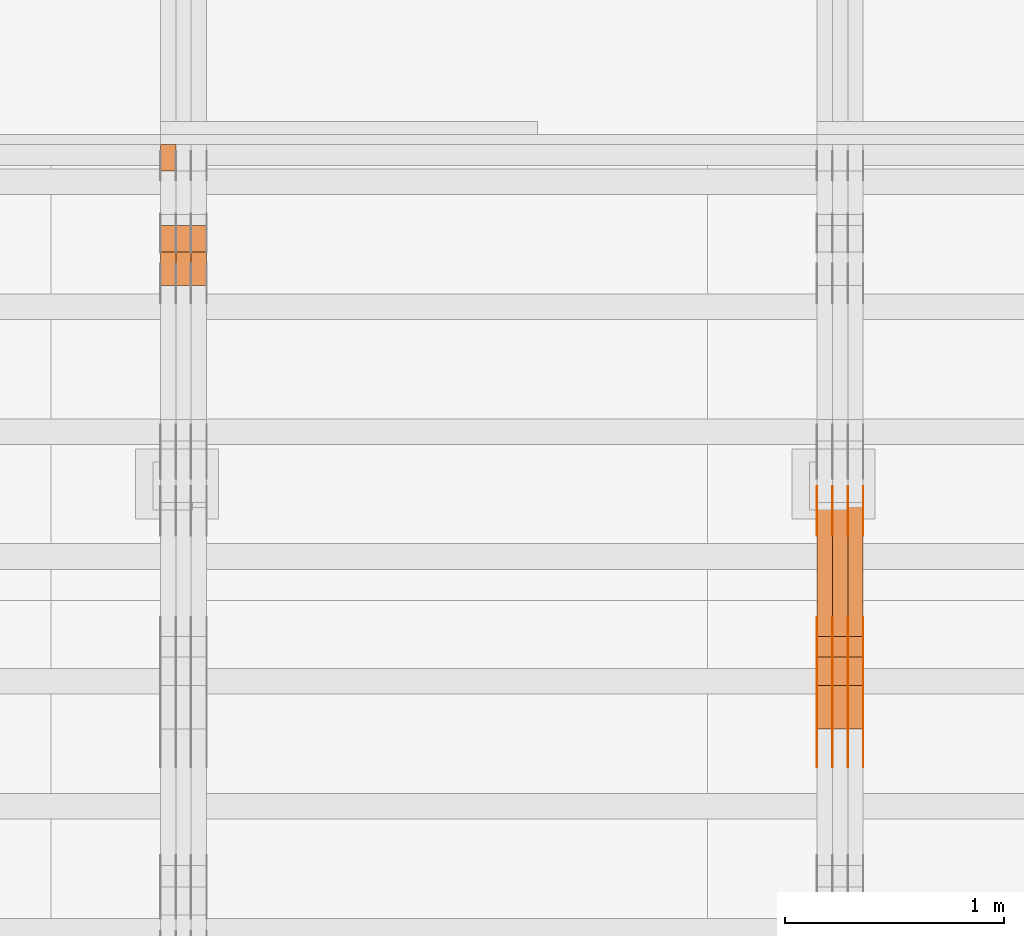
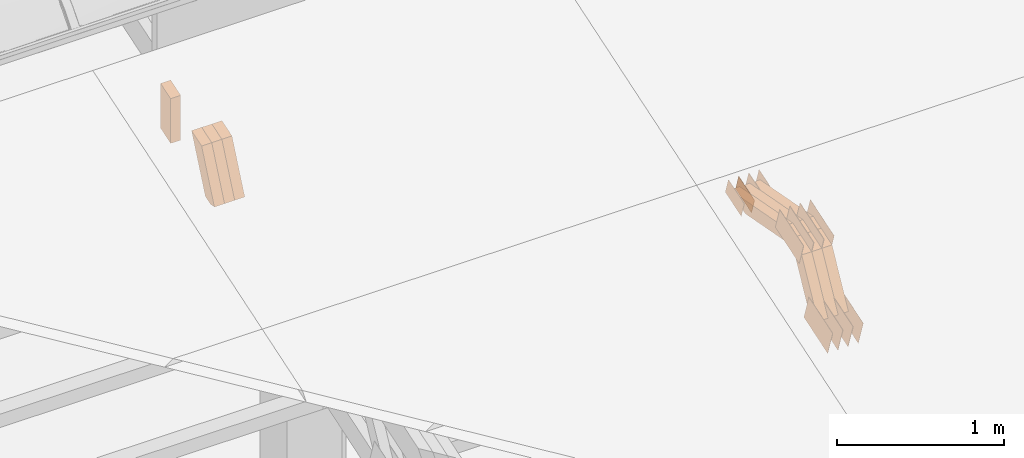
# One storey, part 158 of 385: 28 proxies.
"""IFC2X3 building model written with IfcOpenShell, lengths in millimetres."""

from ifc_helpers import new_model, entity, si_unit, converted_unit, derived_unit, direction, frame, origin, place, context, subcontext, project, spatial, polyline, outline, extrude, source, transform, mapped, material, type_object, type_shapes, element, save


model = new_model("IFC2X3")

# Units and contexts
model_context = context("Model", 3, precision=0.01, world=origin(), true_north=direction((6.12303176911189e-17, 1.0)))
body_context = subcontext(model_context, "Body", "Model", "MODEL_VIEW")
ifc_project = project(units=[si_unit("LENGTHUNIT", "METRE", prefix="MILLI"), si_unit("AREAUNIT", "SQUARE_METRE"), si_unit("VOLUMEUNIT", "CUBIC_METRE"), converted_unit("PLANEANGLEUNIT", "DEGREE", entity("IfcRatioMeasure", 0.0174532925199433), si_unit("PLANEANGLEUNIT", "RADIAN"), dimensions=[0, 0, 0, 0, 0, 0, 0]), si_unit("MASSUNIT", "GRAM", prefix="KILO"), derived_unit("MASSDENSITYUNIT", [(si_unit("MASSUNIT", "GRAM", prefix="KILO"), 1), (si_unit("LENGTHUNIT", "METRE"), -3)]), si_unit("TIMEUNIT", "SECOND"), si_unit("FREQUENCYUNIT", "HERTZ"), si_unit("THERMODYNAMICTEMPERATUREUNIT", "DEGREE_CELSIUS"), derived_unit("THERMALTRANSMITTANCEUNIT", [(si_unit("MASSUNIT", "GRAM", prefix="KILO"), 1), (si_unit("THERMODYNAMICTEMPERATUREUNIT", "KELVIN"), -1), (si_unit("TIMEUNIT", "SECOND"), -3)]), derived_unit("VOLUMETRICFLOWRATEUNIT", [(si_unit("LENGTHUNIT", "METRE"), 3), (si_unit("TIMEUNIT", "SECOND"), -1)]), si_unit("ELECTRICCURRENTUNIT", "AMPERE"), si_unit("ELECTRICVOLTAGEUNIT", "VOLT"), si_unit("POWERUNIT", "WATT"), si_unit("FORCEUNIT", "NEWTON", prefix="KILO"), si_unit("ILLUMINANCEUNIT", "LUX"), si_unit("LUMINOUSFLUXUNIT", "LUMEN"), si_unit("LUMINOUSINTENSITYUNIT", "CANDELA"), derived_unit("USERDEFINED", [(si_unit("MASSUNIT", "GRAM", prefix="KILO"), -1), (si_unit("LENGTHUNIT", "METRE"), -2), (si_unit("TIMEUNIT", "SECOND"), 3), (si_unit("LUMINOUSFLUXUNIT", "LUMEN"), 1)]), derived_unit("LINEARVELOCITYUNIT", [(si_unit("LENGTHUNIT", "METRE"), 1), (si_unit("TIMEUNIT", "SECOND"), -1)]), si_unit("PRESSUREUNIT", "PASCAL"), derived_unit("USERDEFINED", [(si_unit("LENGTHUNIT", "METRE"), -2), (si_unit("MASSUNIT", "GRAM", prefix="KILO"), 1), (si_unit("TIMEUNIT", "SECOND"), -2)])], contexts=[model_context])

# Site, building, storey
site_placement = place(None, origin())
site = spatial("IfcSite", under=ifc_project, at=site_placement, CompositionType="ELEMENT")
building_placement = place(site_placement, origin())
building = spatial("IfcBuilding", under=site, at=building_placement, CompositionType="ELEMENT")
storey_placement = place(building_placement, origin())
storey = spatial("IfcBuildingStorey", under=building, at=storey_placement, Name="Default", CompositionType="ELEMENT", Elevation=0.0)

# Proxies
ifc_material_1 = material(Name="IfcSurfaceStyle #380616")
building_element_proxy_type_1 = type_object("IfcBuildingElementProxyType", PredefinedType="NOTDEFINED", material=ifc_material_1)
shared_shape_1 = source(origin(), body_context, "Body", "SweptSolid", [
    extrude(outline(polyline([(-149.99966632326, -95.9999759039407), (149.999881095801, -95.9999759039407), (150.000557367591, 95.9999759039407), (-150.000772140132, 95.9999759039406), (-149.99966632326, -95.9999759039407)])), frame((150.000557367591, 96.0004291135906, 0.0), z_axis=(0.0, 0.0, 1.0), x_axis=(-1.0, 0.0, 0.0)), (0.0, 0.0, 1.0), 1.29999999999999),
])
type_shapes(building_element_proxy_type_1, [shared_shape_1])
proxy_1_placement = place(building_placement, frame((30386.3, 10934.7734375, 2766.8759765625), z_axis=(-1.0, 0.0, 0.0), x_axis=(0.0, 0.951056516295124, 0.309016994375039)))
element("IfcBuildingElementProxy", 1, at=proxy_1_placement, inside=storey, type_object=building_element_proxy_type_1, material=ifc_material_1, context=body_context, shape_type="MappedRepresentation", body=[
    mapped(shared_shape_1, transform((0.0, 0.0, 0.0), scale=1.0)),
])
ifc_material_2 = material(Name="IfcSurfaceStyle #380559")
building_element_proxy_type_2 = type_object("IfcBuildingElementProxyType", PredefinedType="NOTDEFINED", material=ifc_material_2)
shared_shape_2 = source(origin(), body_context, "Body", "SweptSolid", [
    extrude(outline(polyline([(-149.99966632326, -95.9999759039407), (149.999881095801, -95.9999759039407), (150.000557367591, 95.9999759039407), (-150.000772140132, 95.9999759039406), (-149.99966632326, -95.9999759039407)])), frame((150.000557367591, 96.0004291135906, 0.0), z_axis=(0.0, 0.0, 1.0), x_axis=(-1.0, 0.0, 0.0)), (0.0, 0.0, 1.0), 1.29999999999999),
])
type_shapes(building_element_proxy_type_2, [shared_shape_2])
proxy_2_placement = place(building_placement, frame((30315.0, 10934.7734375, 2766.8759765625), z_axis=(-1.0, 0.0, 0.0), x_axis=(0.0, 0.951056516295124, 0.309016994375039)))
element("IfcBuildingElementProxy", 2, at=proxy_2_placement, inside=storey, type_object=building_element_proxy_type_2, material=ifc_material_2, context=body_context, shape_type="MappedRepresentation", body=[
    mapped(shared_shape_2, transform((0.0, 0.0, 0.0), scale=1.0)),
])
ifc_material_3 = material(Name="IfcSurfaceStyle #380502")
building_element_proxy_type_3 = type_object("IfcBuildingElementProxyType", PredefinedType="NOTDEFINED", material=ifc_material_3)
shared_shape_3 = source(origin(), body_context, "Body", "SweptSolid", [
    extrude(outline(polyline([(-149.99966632326, -95.9999759039407), (149.999881095801, -95.9999759039407), (150.000557367591, 95.9999759039407), (-150.000772140132, 95.9999759039406), (-149.99966632326, -95.9999759039407)])), frame((150.000557367591, 96.0004291135906, 0.0), z_axis=(0.0, 0.0, 1.0), x_axis=(-1.0, 0.0, 0.0)), (0.0, 0.0, 1.0), 1.29999999999999),
])
type_shapes(building_element_proxy_type_3, [shared_shape_3])
proxy_3_placement = place(building_placement, frame((30316.3, 10934.7734375, 2766.8759765625), z_axis=(-1.0, 0.0, 0.0), x_axis=(0.0, 0.951056516295124, 0.309016994375039)))
element("IfcBuildingElementProxy", 3, at=proxy_3_placement, inside=storey, type_object=building_element_proxy_type_3, material=ifc_material_3, context=body_context, shape_type="MappedRepresentation", body=[
    mapped(shared_shape_3, transform((0.0, 0.0, 0.0), scale=1.0)),
])
ifc_material_4 = material(Name="IfcSurfaceStyle #380445")
building_element_proxy_type_4 = type_object("IfcBuildingElementProxyType", PredefinedType="NOTDEFINED", material=ifc_material_4)
shared_shape_4 = source(origin(), body_context, "Body", "SweptSolid", [
    extrude(outline(polyline([(-149.99966632326, -95.9999759039407), (149.999881095801, -95.9999759039407), (150.000557367591, 95.9999759039407), (-150.000772140132, 95.9999759039406), (-149.99966632326, -95.9999759039407)])), frame((150.000557367591, 96.0004291135906, 0.0), z_axis=(0.0, 0.0, 1.0), x_axis=(-1.0, 0.0, 0.0)), (0.0, 0.0, 1.0), 1.29999999999998),
])
type_shapes(building_element_proxy_type_4, [shared_shape_4])
proxy_4_placement = place(building_placement, frame((30245.0, 10934.7734375, 2766.8759765625), z_axis=(-1.0, 0.0, 0.0), x_axis=(0.0, 0.951056516295124, 0.309016994375039)))
element("IfcBuildingElementProxy", 4, at=proxy_4_placement, inside=storey, type_object=building_element_proxy_type_4, material=ifc_material_4, context=body_context, shape_type="MappedRepresentation", body=[
    mapped(shared_shape_4, transform((0.0, 0.0, 0.0), scale=1.0)),
])
ifc_material_5 = material(Name="IfcSurfaceStyle #380388")
building_element_proxy_type_5 = type_object("IfcBuildingElementProxyType", PredefinedType="NOTDEFINED", material=ifc_material_5)
shared_shape_5 = source(origin(), body_context, "Body", "SweptSolid", [
    extrude(outline(polyline([(-149.99966632326, -95.9999759039407), (149.999881095801, -95.9999759039407), (150.000557367591, 95.9999759039407), (-150.000772140132, 95.9999759039406), (-149.99966632326, -95.9999759039407)])), frame((150.000557367591, 96.0004291135906, 0.0), z_axis=(0.0, 0.0, 1.0), x_axis=(-1.0, 0.0, 0.0)), (0.0, 0.0, 1.0), 1.29999999999998),
])
type_shapes(building_element_proxy_type_5, [shared_shape_5])
proxy_5_placement = place(building_placement, frame((30246.3, 10934.7734375, 2766.8759765625), z_axis=(-1.0, 0.0, 0.0), x_axis=(0.0, 0.951056516295124, 0.309016994375039)))
element("IfcBuildingElementProxy", 5, at=proxy_5_placement, inside=storey, type_object=building_element_proxy_type_5, material=ifc_material_5, context=body_context, shape_type="MappedRepresentation", body=[
    mapped(shared_shape_5, transform((0.0, 0.0, 0.0), scale=1.0)),
])
ifc_material_6 = material(Name="IfcSurfaceStyle #380331")
building_element_proxy_type_6 = type_object("IfcBuildingElementProxyType", PredefinedType="NOTDEFINED", material=ifc_material_6)
shared_shape_6 = source(origin(), body_context, "Body", "SweptSolid", [
    extrude(outline(polyline([(-149.99966632326, -95.9999759039407), (149.999881095801, -95.9999759039407), (150.000557367591, 95.9999759039407), (-150.000772140132, 95.9999759039406), (-149.99966632326, -95.9999759039407)])), frame((150.000557367591, 96.0004291135906, 0.0), z_axis=(0.0, 0.0, 1.0), x_axis=(-1.0, 0.0, 0.0)), (0.0, 0.0, 1.0), 1.29999999999998),
])
type_shapes(building_element_proxy_type_6, [shared_shape_6])
proxy_6_placement = place(building_placement, frame((30175.0, 10934.7734375, 2766.8759765625), z_axis=(-1.0, 0.0, 0.0), x_axis=(0.0, 0.951056516295124, 0.309016994375039)))
element("IfcBuildingElementProxy", 6, at=proxy_6_placement, inside=storey, type_object=building_element_proxy_type_6, material=ifc_material_6, context=body_context, shape_type="MappedRepresentation", body=[
    mapped(shared_shape_6, transform((0.0, 0.0, 0.0), scale=1.0)),
])
ifc_material_7 = material(Name="IfcSurfaceStyle #379248")
building_element_proxy_type_7 = type_object("IfcBuildingElementProxyType", PredefinedType="NOTDEFINED", material=ifc_material_7)
shared_shape_7 = source(origin(), body_context, "Body", "SweptSolid", [
    extrude(outline(polyline([(-99.9997874178038, -60.0000528641967), (99.9998102700997, -60.0000528641967), (99.9998251396068, 60.0000528641967), (-99.9998479919027, 60.0000528641967), (-99.9997874178038, -60.0000528641967)])), frame((99.9999918898597, 60.0000528641967, 0.0), z_axis=(0.0, 0.0, 1.0), x_axis=(-1.0, 0.0, 0.0)), (0.0, 0.0, 1.0), 1.3),
])
type_shapes(building_element_proxy_type_7, [shared_shape_7])
proxy_7_placement = place(building_placement, frame((30386.3, 11991.9568177725, 3072.52282247925), z_axis=(-1.0, 0.0, 0.0), x_axis=(0.0, 0.951056516295124, 0.309016994375039)))
element("IfcBuildingElementProxy", 7, at=proxy_7_placement, inside=storey, type_object=building_element_proxy_type_7, material=ifc_material_7, context=body_context, shape_type="MappedRepresentation", body=[
    mapped(shared_shape_7, transform((0.0, 0.0, 0.0), scale=1.0)),
])
ifc_material_8 = material(Name="IfcSurfaceStyle #379191")
building_element_proxy_type_8 = type_object("IfcBuildingElementProxyType", PredefinedType="NOTDEFINED", material=ifc_material_8)
shared_shape_8 = source(origin(), body_context, "Body", "SweptSolid", [
    extrude(outline(polyline([(-99.9997874178038, -60.0000528641967), (99.9998102700997, -60.0000528641967), (99.9998251396068, 60.0000528641967), (-99.9998479919027, 60.0000528641967), (-99.9997874178038, -60.0000528641967)])), frame((99.9999918898597, 60.0000528641967, 0.0), z_axis=(0.0, 0.0, 1.0), x_axis=(-1.0, 0.0, 0.0)), (0.0, 0.0, 1.0), 1.3),
])
type_shapes(building_element_proxy_type_8, [shared_shape_8])
proxy_8_placement = place(building_placement, frame((30315.0, 11991.9568177725, 3072.52282247925), z_axis=(-1.0, 0.0, 0.0), x_axis=(0.0, 0.951056516295124, 0.309016994375039)))
element("IfcBuildingElementProxy", 8, at=proxy_8_placement, inside=storey, type_object=building_element_proxy_type_8, material=ifc_material_8, context=body_context, shape_type="MappedRepresentation", body=[
    mapped(shared_shape_8, transform((0.0, 0.0, 0.0), scale=1.0)),
])
ifc_material_9 = material(Name="IfcSurfaceStyle #379134")
building_element_proxy_type_9 = type_object("IfcBuildingElementProxyType", PredefinedType="NOTDEFINED", material=ifc_material_9)
shared_shape_9 = source(origin(), body_context, "Body", "SweptSolid", [
    extrude(outline(polyline([(-99.9997874178038, -60.0000528641967), (99.9998102700997, -60.0000528641967), (99.9998251396068, 60.0000528641967), (-99.9998479919027, 60.0000528641967), (-99.9997874178038, -60.0000528641967)])), frame((99.9999918898597, 60.0000528641967, 0.0), z_axis=(0.0, 0.0, 1.0), x_axis=(-1.0, 0.0, 0.0)), (0.0, 0.0, 1.0), 1.3),
])
type_shapes(building_element_proxy_type_9, [shared_shape_9])
proxy_9_placement = place(building_placement, frame((30316.3, 11991.9568177725, 3072.52282247925), z_axis=(-1.0, 0.0, 0.0), x_axis=(0.0, 0.951056516295124, 0.309016994375039)))
element("IfcBuildingElementProxy", 9, at=proxy_9_placement, inside=storey, type_object=building_element_proxy_type_9, material=ifc_material_9, context=body_context, shape_type="MappedRepresentation", body=[
    mapped(shared_shape_9, transform((0.0, 0.0, 0.0), scale=1.0)),
])
ifc_material_10 = material(Name="IfcSurfaceStyle #379077")
building_element_proxy_type_10 = type_object("IfcBuildingElementProxyType", PredefinedType="NOTDEFINED", material=ifc_material_10)
shared_shape_10 = source(origin(), body_context, "Body", "SweptSolid", [
    extrude(outline(polyline([(-99.9997874178038, -60.0000528641967), (99.9998102700997, -60.0000528641967), (99.9998251396068, 60.0000528641967), (-99.9998479919027, 60.0000528641967), (-99.9997874178038, -60.0000528641967)])), frame((99.9999918898597, 60.0000528641967, 0.0), z_axis=(0.0, 0.0, 1.0), x_axis=(-1.0, 0.0, 0.0)), (0.0, 0.0, 1.0), 1.29999999999998),
])
type_shapes(building_element_proxy_type_10, [shared_shape_10])
proxy_10_placement = place(building_placement, frame((30245.0, 11991.9568177725, 3072.52282247925), z_axis=(-1.0, 0.0, 0.0), x_axis=(0.0, 0.951056516295124, 0.309016994375039)))
element("IfcBuildingElementProxy", 10, at=proxy_10_placement, inside=storey, type_object=building_element_proxy_type_10, material=ifc_material_10, context=body_context, shape_type="MappedRepresentation", body=[
    mapped(shared_shape_10, transform((0.0, 0.0, 0.0), scale=1.0)),
])
ifc_material_11 = material(Name="IfcSurfaceStyle #379020")
building_element_proxy_type_11 = type_object("IfcBuildingElementProxyType", PredefinedType="NOTDEFINED", material=ifc_material_11)
shared_shape_11 = source(origin(), body_context, "Body", "SweptSolid", [
    extrude(outline(polyline([(-99.9997874178038, -60.0000528641967), (99.9998102700997, -60.0000528641967), (99.9998251396068, 60.0000528641967), (-99.9998479919027, 60.0000528641967), (-99.9997874178038, -60.0000528641967)])), frame((99.9999918898597, 60.0000528641967, 0.0), z_axis=(0.0, 0.0, 1.0), x_axis=(-1.0, 0.0, 0.0)), (0.0, 0.0, 1.0), 1.29999999999998),
])
type_shapes(building_element_proxy_type_11, [shared_shape_11])
proxy_11_placement = place(building_placement, frame((30246.3, 11991.9568177725, 3072.52282247925), z_axis=(-1.0, 0.0, 0.0), x_axis=(0.0, 0.951056516295124, 0.309016994375039)))
element("IfcBuildingElementProxy", 11, at=proxy_11_placement, inside=storey, type_object=building_element_proxy_type_11, material=ifc_material_11, context=body_context, shape_type="MappedRepresentation", body=[
    mapped(shared_shape_11, transform((0.0, 0.0, 0.0), scale=1.0)),
])
ifc_material_12 = material(Name="IfcSurfaceStyle #378963")
building_element_proxy_type_12 = type_object("IfcBuildingElementProxyType", PredefinedType="NOTDEFINED", material=ifc_material_12)
shared_shape_12 = source(origin(), body_context, "Body", "SweptSolid", [
    extrude(outline(polyline([(-99.9997874178038, -60.0000528641967), (99.9998102700997, -60.0000528641967), (99.9998251396068, 60.0000528641967), (-99.9998479919027, 60.0000528641967), (-99.9997874178038, -60.0000528641967)])), frame((99.9999918898597, 60.0000528641967, 0.0), z_axis=(0.0, 0.0, 1.0), x_axis=(-1.0, 0.0, 0.0)), (0.0, 0.0, 1.0), 1.29999999999999),
])
type_shapes(building_element_proxy_type_12, [shared_shape_12])
proxy_12_placement = place(building_placement, frame((30175.0, 11991.9568177725, 3072.52282247925), z_axis=(-1.0, 0.0, 0.0), x_axis=(0.0, 0.951056516295124, 0.309016994375039)))
element("IfcBuildingElementProxy", 12, at=proxy_12_placement, inside=storey, type_object=building_element_proxy_type_12, material=ifc_material_12, context=body_context, shape_type="MappedRepresentation", body=[
    mapped(shared_shape_12, transform((0.0, 0.0, 0.0), scale=1.0)),
])
ifc_material_13 = material(Name="IfcSurfaceStyle #371040")
building_element_proxy_type_13 = type_object("IfcBuildingElementProxyType", PredefinedType="NOTDEFINED", material=ifc_material_13)
shared_shape_13 = source(origin(), body_context, "Body", "SweptSolid", [
    extrude(outline(polyline([(-150.000273478628, -84.0002987844282), (149.999198496832, -84.0002987844282), (150.000273478627, 84.0002987844282), (-149.999198496831, 84.0002987844282), (-150.000273478628, -84.0002987844282)])), frame((150.000273478627, 84.0002987844282, 0.0), z_axis=(0.0, 0.0, 1.0), x_axis=(-1.0, 0.0, 0.0)), (0.0, 0.0, 1.0), 1.29999999999999),
])
type_shapes(building_element_proxy_type_13, [shared_shape_13])
proxy_13_placement = place(building_placement, frame((30386.3, 11283.0116722926, 3194.09682266857), z_axis=(-1.0, 0.0, 0.0), x_axis=(0.0, 0.951056516295154, 0.309016994374948)))
element("IfcBuildingElementProxy", 13, at=proxy_13_placement, inside=storey, type_object=building_element_proxy_type_13, material=ifc_material_13, context=body_context, shape_type="MappedRepresentation", body=[
    mapped(shared_shape_13, transform((0.0, 0.0, 0.0), scale=1.0)),
])
ifc_material_14 = material(Name="IfcSurfaceStyle #370983")
building_element_proxy_type_14 = type_object("IfcBuildingElementProxyType", PredefinedType="NOTDEFINED", material=ifc_material_14)
shared_shape_14 = source(origin(), body_context, "Body", "SweptSolid", [
    extrude(outline(polyline([(-150.000273478628, -84.0002987844282), (149.999198496832, -84.0002987844282), (150.000273478627, 84.0002987844282), (-149.999198496831, 84.0002987844282), (-150.000273478628, -84.0002987844282)])), frame((150.000273478627, 84.0002987844282, 0.0), z_axis=(0.0, 0.0, 1.0), x_axis=(-1.0, 0.0, 0.0)), (0.0, 0.0, 1.0), 1.29999999999999),
])
type_shapes(building_element_proxy_type_14, [shared_shape_14])
proxy_14_placement = place(building_placement, frame((30315.0, 11283.0116722926, 3194.09682266857), z_axis=(-1.0, 0.0, 0.0), x_axis=(0.0, 0.951056516295154, 0.309016994374948)))
element("IfcBuildingElementProxy", 14, at=proxy_14_placement, inside=storey, type_object=building_element_proxy_type_14, material=ifc_material_14, context=body_context, shape_type="MappedRepresentation", body=[
    mapped(shared_shape_14, transform((0.0, 0.0, 0.0), scale=1.0)),
])
ifc_material_15 = material(Name="IfcSurfaceStyle #370926")
building_element_proxy_type_15 = type_object("IfcBuildingElementProxyType", PredefinedType="NOTDEFINED", material=ifc_material_15)
shared_shape_15 = source(origin(), body_context, "Body", "SweptSolid", [
    extrude(outline(polyline([(-150.000273478628, -84.0002987844282), (149.999198496832, -84.0002987844282), (150.000273478627, 84.0002987844282), (-149.999198496831, 84.0002987844282), (-150.000273478628, -84.0002987844282)])), frame((150.000273478627, 84.0002987844282, 0.0), z_axis=(0.0, 0.0, 1.0), x_axis=(-1.0, 0.0, 0.0)), (0.0, 0.0, 1.0), 1.29999999999999),
])
type_shapes(building_element_proxy_type_15, [shared_shape_15])
proxy_15_placement = place(building_placement, frame((30316.3, 11283.0116722926, 3194.09682266857), z_axis=(-1.0, 0.0, 0.0), x_axis=(0.0, 0.951056516295154, 0.309016994374948)))
element("IfcBuildingElementProxy", 15, at=proxy_15_placement, inside=storey, type_object=building_element_proxy_type_15, material=ifc_material_15, context=body_context, shape_type="MappedRepresentation", body=[
    mapped(shared_shape_15, transform((0.0, 0.0, 0.0), scale=1.0)),
])
ifc_material_16 = material(Name="IfcSurfaceStyle #370869")
building_element_proxy_type_16 = type_object("IfcBuildingElementProxyType", PredefinedType="NOTDEFINED", material=ifc_material_16)
shared_shape_16 = source(origin(), body_context, "Body", "SweptSolid", [
    extrude(outline(polyline([(-150.000273478628, -84.0002987844282), (149.999198496832, -84.0002987844282), (150.000273478627, 84.0002987844282), (-149.999198496831, 84.0002987844282), (-150.000273478628, -84.0002987844282)])), frame((150.000273478627, 84.0002987844282, 0.0), z_axis=(0.0, 0.0, 1.0), x_axis=(-1.0, 0.0, 0.0)), (0.0, 0.0, 1.0), 1.29999999999998),
])
type_shapes(building_element_proxy_type_16, [shared_shape_16])
proxy_16_placement = place(building_placement, frame((30245.0, 11283.0116722926, 3194.09682266857), z_axis=(-1.0, 0.0, 0.0), x_axis=(0.0, 0.951056516295154, 0.309016994374948)))
element("IfcBuildingElementProxy", 16, at=proxy_16_placement, inside=storey, type_object=building_element_proxy_type_16, material=ifc_material_16, context=body_context, shape_type="MappedRepresentation", body=[
    mapped(shared_shape_16, transform((0.0, 0.0, 0.0), scale=1.0)),
])
ifc_material_17 = material(Name="IfcSurfaceStyle #370812")
building_element_proxy_type_17 = type_object("IfcBuildingElementProxyType", PredefinedType="NOTDEFINED", material=ifc_material_17)
shared_shape_17 = source(origin(), body_context, "Body", "SweptSolid", [
    extrude(outline(polyline([(-150.000273478628, -84.0002987844282), (149.999198496832, -84.0002987844282), (150.000273478627, 84.0002987844282), (-149.999198496831, 84.0002987844282), (-150.000273478628, -84.0002987844282)])), frame((150.000273478627, 84.0002987844282, 0.0), z_axis=(0.0, 0.0, 1.0), x_axis=(-1.0, 0.0, 0.0)), (0.0, 0.0, 1.0), 1.29999999999998),
])
type_shapes(building_element_proxy_type_17, [shared_shape_17])
proxy_17_placement = place(building_placement, frame((30246.3, 11283.0116722926, 3194.09682266857), z_axis=(-1.0, 0.0, 0.0), x_axis=(0.0, 0.951056516295154, 0.309016994374948)))
element("IfcBuildingElementProxy", 17, at=proxy_17_placement, inside=storey, type_object=building_element_proxy_type_17, material=ifc_material_17, context=body_context, shape_type="MappedRepresentation", body=[
    mapped(shared_shape_17, transform((0.0, 0.0, 0.0), scale=1.0)),
])
ifc_material_18 = material(Name="IfcSurfaceStyle #370755")
building_element_proxy_type_18 = type_object("IfcBuildingElementProxyType", PredefinedType="NOTDEFINED", material=ifc_material_18)
shared_shape_18 = source(origin(), body_context, "Body", "SweptSolid", [
    extrude(outline(polyline([(-150.000273478628, -84.0002987844282), (149.999198496832, -84.0002987844282), (150.000273478627, 84.0002987844282), (-149.999198496831, 84.0002987844282), (-150.000273478628, -84.0002987844282)])), frame((150.000273478627, 84.0002987844282, 0.0), z_axis=(0.0, 0.0, 1.0), x_axis=(-1.0, 0.0, 0.0)), (0.0, 0.0, 1.0), 1.29999999999998),
])
type_shapes(building_element_proxy_type_18, [shared_shape_18])
proxy_18_placement = place(building_placement, frame((30175.0, 11283.0116722926, 3194.09682266857), z_axis=(-1.0, 0.0, 0.0), x_axis=(0.0, 0.951056516295154, 0.309016994374948)))
element("IfcBuildingElementProxy", 18, at=proxy_18_placement, inside=storey, type_object=building_element_proxy_type_18, material=ifc_material_18, context=body_context, shape_type="MappedRepresentation", body=[
    mapped(shared_shape_18, transform((0.0, 0.0, 0.0), scale=1.0)),
])
ifc_material_19 = material(Name="IfcSurfaceStyle #360744")
building_element_proxy_type_19 = type_object("IfcBuildingElementProxyType", Name="T1-W9 360742", PredefinedType="NOTDEFINED", material=ifc_material_19)
shared_shape_19 = source(origin(), body_context, "Body", "SweptSolid", [
    extrude(outline(polyline([(-287.457507623288, -47.5000268597988), (288.590479960635, -47.5000268597988), (273.55062971372, -2.33146189358546e-05), (186.625054999886, 47.5000385171083), (-461.308657050953, 47.5000385171083), (-287.457507623288, -47.5000268597988)])), frame((288.590945855618, 47.5000968036551, 0.0), z_axis=(0.0, 0.0, 1.0), x_axis=(-1.0, 0.0, 0.0)), (0.0, 0.0, 1.0), 70.0),
])
type_shapes(building_element_proxy_type_19, [shared_shape_19])
proxy_19_placement = place(building_placement, frame((30385.0, 11432.1200855376, 3205.63308612017), z_axis=(-1.0, 0.0, 0.0), x_axis=(0.0, 0.982760503514031, -0.184883186722992)))
element("IfcBuildingElementProxy", 19, at=proxy_19_placement, inside=storey, type_object=building_element_proxy_type_19, material=ifc_material_19, Name="T1-W9", context=body_context, shape_type="MappedRepresentation", body=[
    mapped(shared_shape_19, transform((0.0, 0.0, 0.0), scale=1.0)),
])
ifc_material_20 = material(Name="IfcSurfaceStyle #360678")
building_element_proxy_type_20 = type_object("IfcBuildingElementProxyType", Name="T1-W9 360676", PredefinedType="NOTDEFINED", material=ifc_material_20)
shared_shape_20 = source(origin(), body_context, "Body", "SweptSolid", [
    extrude(outline(polyline([(-287.457507623288, -47.5000268597988), (288.590479960635, -47.5000268597988), (273.55062971372, -2.33146189358546e-05), (186.625054999886, 47.5000385171083), (-461.308657050953, 47.5000385171083), (-287.457507623288, -47.5000268597988)])), frame((288.590945855618, 47.5000968036551, 0.0), z_axis=(0.0, 0.0, 1.0), x_axis=(-1.0, 0.0, 0.0)), (0.0, 0.0, 1.0), 70.0),
])
type_shapes(building_element_proxy_type_20, [shared_shape_20])
proxy_20_placement = place(building_placement, frame((30315.0, 11432.1200855376, 3205.63308612017), z_axis=(-1.0, 0.0, 0.0), x_axis=(0.0, 0.982760503514031, -0.184883186722992)))
element("IfcBuildingElementProxy", 20, at=proxy_20_placement, inside=storey, type_object=building_element_proxy_type_20, material=ifc_material_20, Name="T1-W9", context=body_context, shape_type="MappedRepresentation", body=[
    mapped(shared_shape_20, transform((0.0, 0.0, 0.0), scale=1.0)),
])
ifc_material_21 = material(Name="IfcSurfaceStyle #360612")
building_element_proxy_type_21 = type_object("IfcBuildingElementProxyType", Name="T1-W9 360610", PredefinedType="NOTDEFINED", material=ifc_material_21)
shared_shape_21 = source(origin(), body_context, "Body", "SweptSolid", [
    extrude(outline(polyline([(-287.457507623288, -47.5000268597988), (288.590479960635, -47.5000268597988), (273.55062971372, -2.33146189358546e-05), (186.625054999886, 47.5000385171083), (-461.308657050953, 47.5000385171083), (-287.457507623288, -47.5000268597988)])), frame((288.590945855618, 47.5000968036551, 0.0), z_axis=(0.0, 0.0, 1.0), x_axis=(-1.0, 0.0, 0.0)), (0.0, 0.0, 1.0), 70.0),
])
type_shapes(building_element_proxy_type_21, [shared_shape_21])
proxy_21_placement = place(building_placement, frame((30245.0, 11432.1200855376, 3205.63308612017), z_axis=(-1.0, 0.0, 0.0), x_axis=(0.0, 0.982760503514031, -0.184883186722992)))
element("IfcBuildingElementProxy", 21, at=proxy_21_placement, inside=storey, type_object=building_element_proxy_type_21, material=ifc_material_21, Name="T1-W9", context=body_context, shape_type="MappedRepresentation", body=[
    mapped(shared_shape_21, transform((0.0, 0.0, 0.0), scale=1.0)),
])
ifc_material_22 = material(Name="IfcSurfaceStyle #360348")
building_element_proxy_type_22 = type_object("IfcBuildingElementProxyType", Name="T1-W32 360346", PredefinedType="NOTDEFINED", material=ifc_material_22)
shared_shape_22 = source(origin(), body_context, "Body", "SweptSolid", [
    extrude(outline(polyline([(-312.414547135921, -47.5000544873059), (136.677011757652, -47.5000544873059), (186.250996577889, 0.000369497452627243), (202.753116295831, 47.4998697385796), (-213.26657749545, 47.4998697385796), (-312.414547135921, -47.5000544873059)])), frame((202.753376481939, 47.5001296985553, 0.0), z_axis=(0.0, 0.0, 1.0), x_axis=(-1.0, 0.0, 0.0)), (0.0, 0.0, 1.0), 70.0),
])
type_shapes(building_element_proxy_type_22, [shared_shape_22])
proxy_22_placement = place(building_placement, frame((30385.0, 11110.7808979007, 2747.18129017315), z_axis=(-1.0, 0.0, 0.0), x_axis=(0.0, 0.472919689385906, 0.881105537033526)))
element("IfcBuildingElementProxy", 22, at=proxy_22_placement, inside=storey, type_object=building_element_proxy_type_22, material=ifc_material_22, Name="T1-W32", context=body_context, shape_type="MappedRepresentation", body=[
    mapped(shared_shape_22, transform((0.0, 0.0, 0.0), scale=1.0)),
])
ifc_material_23 = material(Name="IfcSurfaceStyle #360282")
building_element_proxy_type_23 = type_object("IfcBuildingElementProxyType", Name="T1-W32 360280", PredefinedType="NOTDEFINED", material=ifc_material_23)
shared_shape_23 = source(origin(), body_context, "Body", "SweptSolid", [
    extrude(outline(polyline([(-312.414547135921, -47.5000544873059), (136.677011757652, -47.5000544873059), (186.250996577889, 0.000369497452627243), (202.753116295831, 47.4998697385796), (-213.26657749545, 47.4998697385796), (-312.414547135921, -47.5000544873059)])), frame((202.753376481939, 47.5001296985553, 0.0), z_axis=(0.0, 0.0, 1.0), x_axis=(-1.0, 0.0, 0.0)), (0.0, 0.0, 1.0), 70.0),
])
type_shapes(building_element_proxy_type_23, [shared_shape_23])
proxy_23_placement = place(building_placement, frame((30315.0, 11110.7808979007, 2747.18129017315), z_axis=(-1.0, 0.0, 0.0), x_axis=(0.0, 0.472919689385906, 0.881105537033526)))
element("IfcBuildingElementProxy", 23, at=proxy_23_placement, inside=storey, type_object=building_element_proxy_type_23, material=ifc_material_23, Name="T1-W32", context=body_context, shape_type="MappedRepresentation", body=[
    mapped(shared_shape_23, transform((0.0, 0.0, 0.0), scale=1.0)),
])
ifc_material_24 = material(Name="IfcSurfaceStyle #360216")
building_element_proxy_type_24 = type_object("IfcBuildingElementProxyType", Name="T1-W32 360214", PredefinedType="NOTDEFINED", material=ifc_material_24)
shared_shape_24 = source(origin(), body_context, "Body", "SweptSolid", [
    extrude(outline(polyline([(-312.414547135921, -47.5000544873059), (136.677011757652, -47.5000544873059), (186.250996577889, 0.000369497452627243), (202.753116295831, 47.4998697385796), (-213.26657749545, 47.4998697385796), (-312.414547135921, -47.5000544873059)])), frame((202.753376481939, 47.5001296985553, 0.0), z_axis=(0.0, 0.0, 1.0), x_axis=(-1.0, 0.0, 0.0)), (0.0, 0.0, 1.0), 70.0),
])
type_shapes(building_element_proxy_type_24, [shared_shape_24])
proxy_24_placement = place(building_placement, frame((30245.0, 11110.7808979007, 2747.18129017315), z_axis=(-1.0, 0.0, 0.0), x_axis=(0.0, 0.472919689385906, 0.881105537033526)))
element("IfcBuildingElementProxy", 24, at=proxy_24_placement, inside=storey, type_object=building_element_proxy_type_24, material=ifc_material_24, Name="T1-W32", context=body_context, shape_type="MappedRepresentation", body=[
    mapped(shared_shape_24, transform((0.0, 0.0, 0.0), scale=1.0)),
])
ifc_material_25 = material(Name="IfcSurfaceStyle #327926")
building_element_proxy_type_25 = type_object("IfcBuildingElementProxyType", Name="T1-W1 327924", PredefinedType="NOTDEFINED", material=ifc_material_25)
shared_shape_25 = source(origin(), body_context, "Body", "SweptSolid", [
    extrude(outline(polyline([(-182.839782714844, -60.0), (143.849426269531, -60.0), (182.839660644531, 60.0), (-143.849304199219, 60.0), (-182.839782714844, -60.0)])), frame((182.839674685549, 60.0, 0.0), z_axis=(0.0, 0.0, 1.0), x_axis=(-1.0, 0.0, 0.0)), (0.0, 0.0, 1.0), 70.0),
])
type_shapes(building_element_proxy_type_25, [shared_shape_25])
proxy_25_placement = place(building_placement, frame((27245.0, 13660.0, 3551.41502502148), z_axis=(-1.0, 0.0, 0.0), x_axis=(0.0, 0.0, 1.0)))
element("IfcBuildingElementProxy", 25, at=proxy_25_placement, inside=storey, type_object=building_element_proxy_type_25, material=ifc_material_25, Name="T1-W1", context=body_context, shape_type="MappedRepresentation", body=[
    mapped(shared_shape_25, transform((0.0, 0.0, 0.0), scale=1.0)),
])
ifc_material_26 = material(Name="IfcSurfaceStyle #327500")
building_element_proxy_type_26 = type_object("IfcBuildingElementProxyType", Name="T1-W42 327498", PredefinedType="NOTDEFINED", material=ifc_material_26)
shared_shape_26 = source(origin(), body_context, "Body", "SweptSolid", [
    extrude(outline(polyline([(-284.837590197601, -47.4997543607933), (129.95880168156, -47.4997543607933), (171.972324990451, 0.000162623346093338), (183.717007105413, 47.4996730491203), (-200.810543579822, 47.4996730491203), (-284.837590197601, -47.4997543607933)])), frame((183.717155718752, 47.4999821655365, 0.0), z_axis=(0.0, 0.0, 1.0), x_axis=(-1.0, 0.0, 0.0)), (0.0, 0.0, 1.0), 70.0),
])
type_shapes(building_element_proxy_type_26, [shared_shape_26])
proxy_26_placement = place(building_placement, frame((27385.0, 13135.8834463264, 3404.958483022), z_axis=(-1.0, 0.0, 0.0), x_axis=(0.0, 0.398630596470292, 0.917111578575769)))
element("IfcBuildingElementProxy", 26, at=proxy_26_placement, inside=storey, type_object=building_element_proxy_type_26, material=ifc_material_26, Name="T1-W42", context=body_context, shape_type="MappedRepresentation", body=[
    mapped(shared_shape_26, transform((0.0, 0.0, 0.0), scale=1.0)),
])
ifc_material_27 = material(Name="IfcSurfaceStyle #327434")
building_element_proxy_type_27 = type_object("IfcBuildingElementProxyType", Name="T1-W42 327432", PredefinedType="NOTDEFINED", material=ifc_material_27)
shared_shape_27 = source(origin(), body_context, "Body", "SweptSolid", [
    extrude(outline(polyline([(-284.837590197601, -47.4997543607933), (129.95880168156, -47.4997543607933), (171.972324990451, 0.000162623346093338), (183.717007105413, 47.4996730491203), (-200.810543579822, 47.4996730491203), (-284.837590197601, -47.4997543607933)])), frame((183.717155718752, 47.4999821655365, 0.0), z_axis=(0.0, 0.0, 1.0), x_axis=(-1.0, 0.0, 0.0)), (0.0, 0.0, 1.0), 70.0),
])
type_shapes(building_element_proxy_type_27, [shared_shape_27])
proxy_27_placement = place(building_placement, frame((27315.0, 13135.8834463264, 3404.958483022), z_axis=(-1.0, 0.0, 0.0), x_axis=(0.0, 0.398630596470292, 0.917111578575769)))
element("IfcBuildingElementProxy", 27, at=proxy_27_placement, inside=storey, type_object=building_element_proxy_type_27, material=ifc_material_27, Name="T1-W42", context=body_context, shape_type="MappedRepresentation", body=[
    mapped(shared_shape_27, transform((0.0, 0.0, 0.0), scale=1.0)),
])
ifc_material_28 = material(Name="IfcSurfaceStyle #327368")
building_element_proxy_type_28 = type_object("IfcBuildingElementProxyType", Name="T1-W42 327366", PredefinedType="NOTDEFINED", material=ifc_material_28)
shared_shape_28 = source(origin(), body_context, "Body", "SweptSolid", [
    extrude(outline(polyline([(-284.837590197601, -47.4997543607933), (129.95880168156, -47.4997543607933), (171.972324990451, 0.000162623346093338), (183.717007105413, 47.4996730491203), (-200.810543579822, 47.4996730491203), (-284.837590197601, -47.4997543607933)])), frame((183.717155718752, 47.4999821655365, 0.0), z_axis=(0.0, 0.0, 1.0), x_axis=(-1.0, 0.0, 0.0)), (0.0, 0.0, 1.0), 70.0),
])
type_shapes(building_element_proxy_type_28, [shared_shape_28])
proxy_28_placement = place(building_placement, frame((27245.0, 13135.8834463264, 3404.958483022), z_axis=(-1.0, 0.0, 0.0), x_axis=(0.0, 0.398630596470292, 0.917111578575769)))
element("IfcBuildingElementProxy", 28, at=proxy_28_placement, inside=storey, type_object=building_element_proxy_type_28, material=ifc_material_28, Name="T1-W42", context=body_context, shape_type="MappedRepresentation", body=[
    mapped(shared_shape_28, transform((0.0, 0.0, 0.0), scale=1.0)),
])

save(model, "model.ifc")
